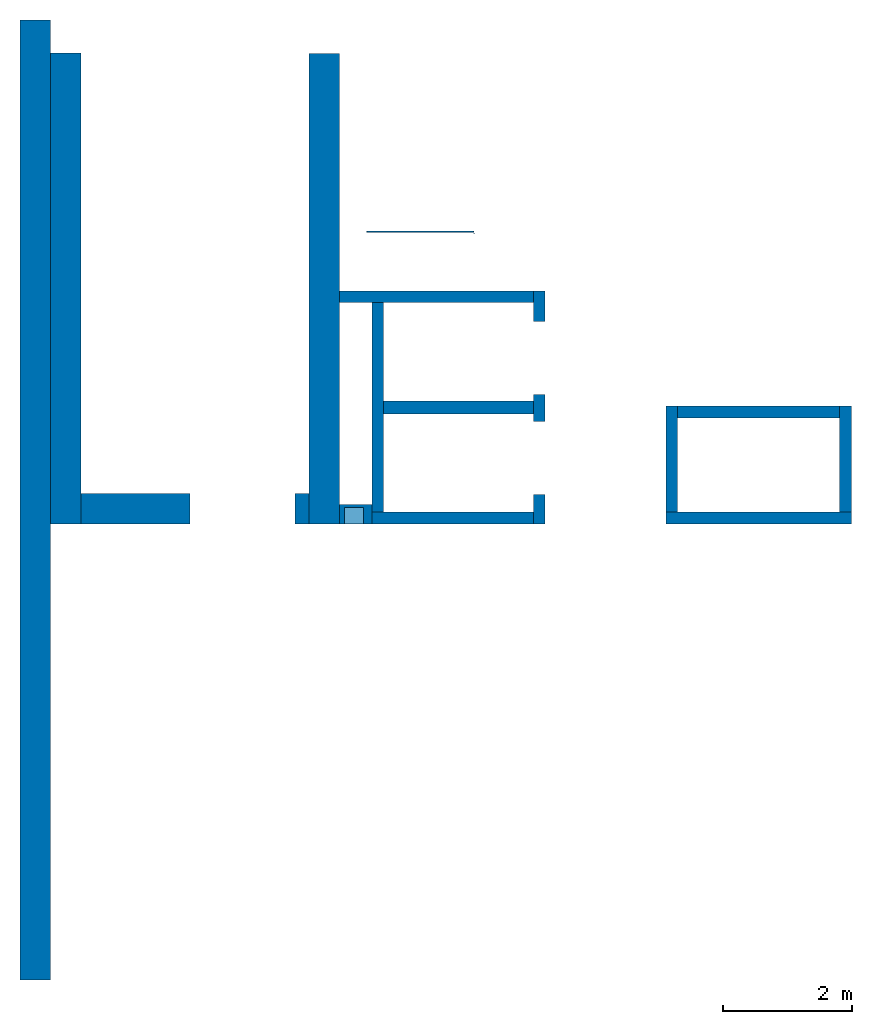
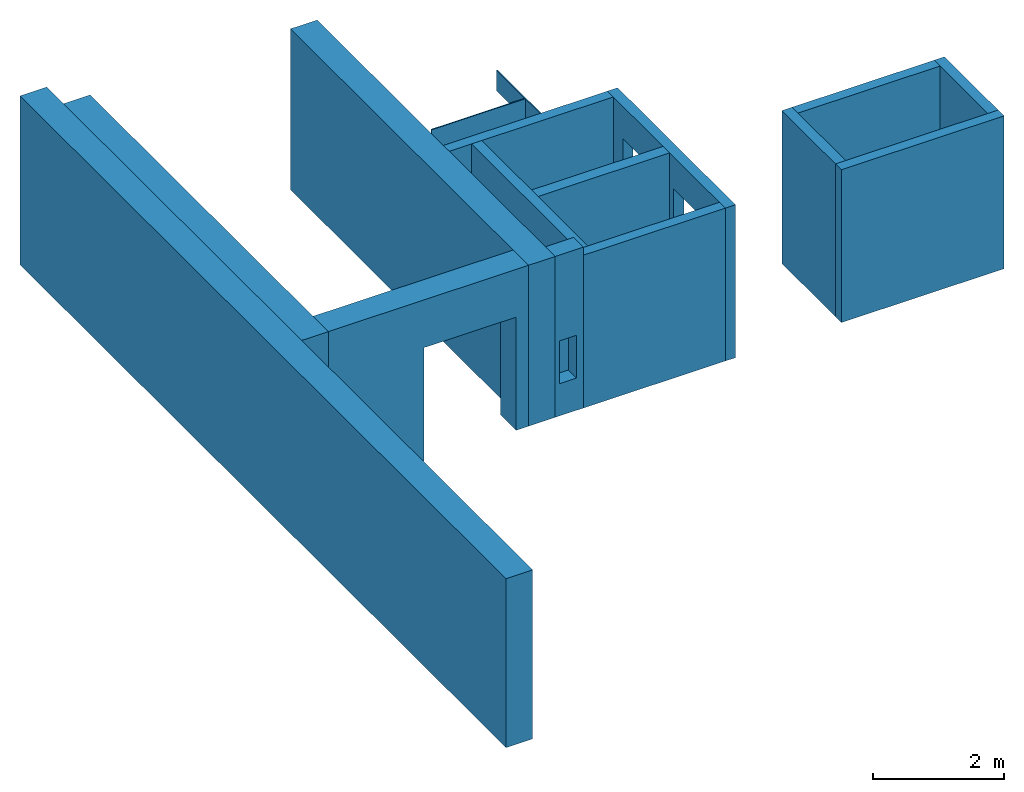
# One storey: 16 walls, 6 openings.
"""IFC4 building model written with IfcOpenShell, lengths in metres."""

from ifc_helpers import new_model, entity, si_unit, converted_unit, derived_unit, direction, frame, origin_with_axes, place, context, subcontext, project, spatial, polygons, material, type_object, element, save


model = new_model("IFC4")

# Units and contexts
model_context = context("Model", 3, precision=1e-05, world=origin_with_axes(), true_north=direction((0.0, 1.0)))
body_context = subcontext(model_context, "Body", "Model", "MODEL_VIEW")
ifc_project = project(units=[si_unit("LENGTHUNIT", "METRE"), si_unit("AREAUNIT", "SQUARE_METRE"), si_unit("VOLUMEUNIT", "CUBIC_METRE"), converted_unit("PLANEANGLEUNIT", "DEGREE", entity("IfcPlaneAngleMeasure", 0.0174532925199433), si_unit("PLANEANGLEUNIT", "RADIAN"), dimensions=[0, 0, 0, 0, 0, 0, 0]), converted_unit("TIMEUNIT", "Year", entity("IfcTimeMeasure", 31557600.0), si_unit("TIMEUNIT", "SECOND"), dimensions=[0, 0, 1, 0, 0, 0, 0]), si_unit("MASSUNIT", "GRAM", prefix="KILO"), si_unit("THERMODYNAMICTEMPERATUREUNIT", "DEGREE_CELSIUS"), si_unit("LUMINOUSINTENSITYUNIT", "LUMEN"), si_unit("ENERGYUNIT", "JOULE", prefix="MEGA"), derived_unit("THERMALCONDUCTANCEUNIT", [(si_unit("POWERUNIT", "WATT"), 1), (si_unit("LENGTHUNIT", "METRE"), -1), (si_unit("THERMODYNAMICTEMPERATUREUNIT", "KELVIN"), -1)]), derived_unit("SPECIFICHEATCAPACITYUNIT", [(si_unit("ENERGYUNIT", "JOULE"), 1), (si_unit("MASSUNIT", "GRAM", prefix="KILO"), -1), (si_unit("THERMODYNAMICTEMPERATUREUNIT", "KELVIN"), -1)]), derived_unit("MASSDENSITYUNIT", [(si_unit("MASSUNIT", "GRAM", prefix="KILO"), 1), (si_unit("VOLUMEUNIT", "CUBIC_METRE"), -1)])], contexts=[model_context])

# Site, building, storey
site_placement = place(None, origin_with_axes())
site = spatial("IfcSite", under=ifc_project, at=site_placement, CompositionType="ELEMENT")
building_placement = place(None, origin_with_axes())
building = spatial("IfcBuilding", under=site, at=building_placement, CompositionType="ELEMENT")
storey_placement = place(None, frame((0.0, 0.0, 7.5), z_axis=(0.0, 0.0, 1.0), x_axis=(1.0, 0.0, 0.0)))
storey = spatial("IfcBuildingStorey", under=building, at=storey_placement, Name="2 OG", CompositionType="ELEMENT", Elevation=7.5)

# Wall
ifc_material_1 = material(Name="Stahlbeton")
wall_type_1 = type_object("IfcWallType", Name="Stahlbeton 180", PredefinedType="NOTDEFINED")
wall_1_placement = place(None, frame((31.638, 10.6549999454676, 7.5), z_axis=(0.0, 0.0, 1.0), x_axis=(-1.0, 0.0, 0.0)))
element("IfcWall", 1, at=wall_1_placement, inside=storey, type_object=wall_type_1, material=ifc_material_1, Name="Wand-003", PredefinedType="NOTDEFINED", context=body_context, shape_type="Tessellation", body=[
    polygons([(3.18, 0.18, 2.85), (0.179999999999996, 0.18, 2.85), (0.179999999999996, 0.0, 2.85), (3.18, 0.0, 2.85), (3.18, 0.18, 0.0), (0.179999999999996, 0.18, 0.0), (0.179999999999996, 0.0, 0.0), (3.18, 0.0, 0.0)], [[[1, 2, 3, 4]], [[5, 6, 2, 1]], [[6, 7, 3, 2]], [[4, 3, 7, 8]], [[1, 4, 8, 5]], [[8, 7, 6, 5]]], closed=True),
])

# Wall, openings
wall_2_placement = place(None, frame((31.638, 7.05499994546755, 7.5), z_axis=(0.0, 0.0, 1.0), x_axis=(0.0, 1.0, 0.0)))
wall_2 = element("IfcWall", 2, at=wall_2_placement, inside=storey, type_object=wall_type_1, material=ifc_material_1, Name="Wand-002", PredefinedType="NOTDEFINED", context=body_context, shape_type="Tessellation", body=[
    polygons([(2.0, 0.0, 0.0), (2.0, 0.0, 2.25), (3.13, 0.0, 2.25), (3.13, 0.0, 0.0), (3.6, 0.0, 0.0), (3.6, 0.0, 2.85), (0.0, 0.0, 2.85), (0.0, 0.0, 0.0), (0.450000000000002, 0.0, 0.0), (0.450000000000002, 0.0, 2.25), (1.58, 0.0, 2.25), (1.58, 0.0, 0.0), (2.0, 0.179999999999996, 0.0), (2.0, 0.179999999999996, 2.25), (3.13, 0.179999999999996, 2.25), (3.13, 0.179999999999996, 0.0), (3.6, 0.179999999999996, 0.0), (3.6, 0.179999999999996, 2.85), (0.0, 0.18, 2.85), (0.0, 0.18, 0.0), (0.450000000000002, 0.18, 0.0), (0.450000000000002, 0.18, 2.25), (1.58, 0.18, 2.25), (1.58, 0.18, 0.0)], [[[1, 2, 3, 4, 5, 6, 7, 8, 9, 10, 11, 12]], [[2, 1, 13, 14]], [[3, 2, 14, 15]], [[4, 3, 15, 16]], [[4, 16, 17, 5]], [[6, 5, 17, 18]], [[6, 18, 19, 7]], [[19, 20, 8, 7]], [[9, 8, 20, 21]], [[9, 21, 22, 10]], [[10, 22, 23, 11]], [[11, 23, 24, 12]], [[13, 1, 12, 24]], [[14, 13, 24, 23, 22, 21, 20, 19, 18, 17, 16, 15]]], closed=True),
])
opening_1_placement = place(wall_2_placement, frame((1.015, 0.0, 0.0), z_axis=(0.0, 0.0, 1.0), x_axis=(1.0, 0.0, 0.0)))
element("IfcOpeningElement", 3, at=opening_1_placement, cuts=wall_2, context=body_context, identifier="Reference", shape_type="Tessellation", body=[
    polygons([(-0.565, -0.00100000000000122, 2.25), (-0.565, -0.00100000000000122, 0.0), (0.565, -0.00100000000000122, 0.0), (0.565, -0.00100000000000122, 2.25), (-0.565, 0.181000000000004, 2.25), (-0.565, 0.181000000000004, 0.0), (0.565000000000001, 0.181000000000004, 0.0), (0.565000000000001, 0.181000000000004, 2.25)], [[[1, 2, 3, 4]], [[5, 6, 2, 1]], [[6, 7, 3, 2]], [[7, 8, 4, 3]], [[8, 5, 1, 4]], [[7, 6, 5, 8]]], closed=True),
])
opening_2_placement = place(wall_2_placement, frame((2.565, 0.0, 0.0), z_axis=(0.0, 0.0, 1.0), x_axis=(1.0, 0.0, 0.0)))
element("IfcOpeningElement", 4, at=opening_2_placement, cuts=wall_2, context=body_context, identifier="Reference", shape_type="Tessellation", body=[
    polygons([(-0.565, -0.00100000000000478, 2.25), (-0.565, -0.00100000000000478, 0.0), (0.565, -0.00100000000000478, 0.0), (0.565, -0.00100000000000478, 2.25), (-0.564999999999998, 0.181000000000001, 2.25), (-0.564999999999998, 0.181000000000001, 0.0), (0.565000000000001, 0.181000000000001, 0.0), (0.565000000000001, 0.181000000000001, 2.25)], [[[1, 2, 3, 4]], [[5, 6, 2, 1]], [[6, 7, 3, 2]], [[7, 8, 4, 3]], [[8, 5, 1, 4]], [[7, 6, 5, 8]]], closed=True),
])

# Walls
wall_3_placement = place(None, frame((33.505, 7.05499994546756, 7.5), z_axis=(0.0, 0.0, 1.0), x_axis=(0.0, 1.0, 0.0)))
element("IfcWall", 5, at=wall_3_placement, inside=storey, type_object=wall_type_1, material=ifc_material_1, Name="Wand-001", PredefinedType="NOTDEFINED", context=body_context, shape_type="Tessellation", body=[
    polygons([(1.818, 0.0, 0.0), (1.818, 0.0, 2.85), (1.818, -0.18, 2.85), (1.818, -0.18, 0.0), (0.18, 0.0, 0.0), (0.180000000000001, 0.0, 2.85), (0.180000000000001, -0.18, 2.85), (0.18, -0.18, 0.0)], [[[1, 2, 3, 4]], [[5, 6, 2, 1]], [[6, 7, 3, 2]], [[4, 3, 7, 8]], [[4, 8, 5, 1]], [[8, 7, 6, 5]]], closed=True),
])
wall_4_placement = place(None, frame((28.958, 7.05499994546755, 7.5), z_axis=(0.0, 0.0, 1.0), x_axis=(1.0, 0.0, 0.0)))
element("IfcWall", 6, at=wall_4_placement, inside=storey, type_object=wall_type_1, material=ifc_material_1, Name="Wand-001", PredefinedType="NOTDEFINED", context=body_context, shape_type="Tessellation", body=[
    polygons([(0.0, 0.0, 2.85), (2.5, 0.0, 2.85), (2.5, 0.180000000000002, 2.85), (0.0, 0.18, 2.85), (0.0, 0.0, 0.0), (2.5, 0.0, 0.0), (2.5, 0.180000000000001, 0.0), (0.0, 0.18, 0.0)], [[[1, 2, 3, 4]], [[5, 6, 2, 1]], [[6, 7, 3, 2]], [[4, 3, 7, 8]], [[5, 1, 4, 8]], [[8, 7, 6, 5]]], closed=True),
])
wall_5_placement = place(None, frame((36.373, 8.87299994546756, 7.5), z_axis=(0.0, 0.0, 1.0), x_axis=(-1.0, 0.0, 0.0)))
element("IfcWall", 7, at=wall_5_placement, inside=storey, type_object=wall_type_1, material=ifc_material_1, Name="Wand-001", PredefinedType="NOTDEFINED", context=body_context, shape_type="Tessellation", body=[
    polygons([(2.688, 0.18, 2.85), (0.18, 0.18, 2.85), (0.18, 0.0, 2.85), (2.688, 0.0, 2.85), (2.688, 0.18, 0.0), (0.18, 0.18, 0.0), (0.18, 0.0, 0.0), (2.688, 0.0, 0.0)], [[[1, 2, 3, 4]], [[5, 6, 2, 1]], [[6, 7, 3, 2]], [[4, 3, 7, 8]], [[5, 1, 4, 8]], [[8, 7, 6, 5]]], closed=True),
])
wall_6_placement = place(None, frame((36.373, 7.05499994546756, 7.5), z_axis=(0.0, 0.0, 1.0), x_axis=(0.0, 1.0, 0.0)))
element("IfcWall", 8, at=wall_6_placement, inside=storey, type_object=wall_type_1, material=ifc_material_1, Name="Wand-001", PredefinedType="NOTDEFINED", context=body_context, shape_type="Tessellation", body=[
    polygons([(1.818, 0.18, 0.0), (1.818, 0.18, 2.85), (1.818, 0.0, 2.85), (1.818, 0.0, 0.0), (0.180000000000001, 0.18, 0.0), (0.180000000000001, 0.18, 2.85), (0.180000000000001, 0.0, 2.85), (0.180000000000001, 0.0, 0.0)], [[[1, 2, 3, 4]], [[5, 6, 2, 1]], [[6, 7, 3, 2]], [[4, 3, 7, 8]], [[4, 8, 5, 1]], [[8, 7, 6, 5]]], closed=True),
])
wall_7_placement = place(None, frame((33.505, 7.05499994546756, 7.5), z_axis=(0.0, 0.0, 1.0), x_axis=(1.0, 0.0, 0.0)))
element("IfcWall", 9, at=wall_7_placement, inside=storey, type_object=wall_type_1, material=ifc_material_1, Name="Wand-001", PredefinedType="NOTDEFINED", context=body_context, shape_type="Tessellation", body=[
    polygons([(0.0, 0.18, 0.0), (0.0, 0.18, 2.85), (2.868, 0.180000000000001, 2.84999999940395), (2.868, 0.180000000000001, 0.0), (0.0, 0.0, 0.0), (0.0, 0.0, 2.85), (2.868, 0.0, 2.84999999940395), (2.868, 0.0, 0.0)], [[[1, 2, 3, 4]], [[5, 6, 2, 1]], [[6, 7, 3, 2]], [[4, 3, 7, 8]], [[5, 1, 4, 8]], [[8, 7, 6, 5]]], closed=True),
])
wall_8_placement = place(None, frame((29.138, 7.05499994546755, 7.5), z_axis=(0.0, 0.0, 1.0), x_axis=(0.0, 1.0, 0.0)))
element("IfcWall", 10, at=wall_8_placement, inside=storey, type_object=wall_type_1, material=ifc_material_1, Name="Wand-003", PredefinedType="NOTDEFINED", context=body_context, shape_type="Tessellation", body=[
    polygons([(3.42, 0.18, 2.85), (0.180000000000001, 0.18, 2.85), (0.180000000000001, 0.0, 2.85), (3.42, 0.0, 2.85), (3.42, 0.18, 0.0), (0.18, 0.18, 0.0), (0.18, 0.0, 0.0), (3.42, 0.0, 0.0)], [[[1, 2, 3, 4]], [[5, 6, 2, 1]], [[6, 7, 3, 2]], [[4, 3, 7, 8]], [[5, 1, 4, 8]], [[8, 7, 6, 5]]], closed=True),
])

# Space
space_placement = place(None, frame((28.883, 12.4404999136732, 7.5), z_axis=(0.0, 0.0, 1.0), x_axis=(0.0, -1.0, 0.0)))
space = spatial("IfcSpace", under=storey, at=space_placement, CompositionType="ELEMENT", PredefinedType="NOTDEFINED")

# Wall
ifc_material_2 = material(Name="Kunststoff")
wall_type_2 = type_object("IfcWallType", Name="Kunststoff 20", PredefinedType="NOTDEFINED")
wall_9_placement = place(None, frame((30.553, 11.5727499295704, 7.35), z_axis=(0.0, 0.0, 1.0), x_axis=(-1.0, 0.0, 0.0)))
element("IfcWall", 11, at=wall_9_placement, inside=space, type_object=wall_type_2, material=ifc_material_2, Name="Wand-003", PredefinedType="NOTDEFINED", context=body_context, shape_type="Tessellation", body=[
    polygons([(0.0199999999999996, -0.00999999999999979, 2.63), (0.0199999999999996, 0.00999999999999979, 2.63), (0.0199999999999996, 0.00999999999999979, 0.15), (0.0199999999999996, -0.00999999999999979, 0.15), (1.67, -0.00999999999999979, 2.63), (1.67, 0.00999999999999979, 2.63), (1.67, 0.00999999999999979, 0.15), (1.67, -0.00999999999999979, 0.15)], [[[1, 2, 3, 4]], [[2, 1, 5, 6]], [[2, 6, 7, 3]], [[3, 7, 8, 4]], [[5, 1, 4, 8]], [[6, 5, 8, 7]]], closed=True),
])

# Wall, openings
wall_10_placement = place(None, frame((30.553, 10.6549999454676, 7.35), z_axis=(0.0, 0.0, 1.0), x_axis=(0.0, 1.0, 0.0)))
wall_10 = element("IfcWall", 12, at=wall_10_placement, inside=space, type_object=wall_type_2, material=ifc_material_2, Name="Wand-003", PredefinedType="NOTDEFINED", context=body_context, shape_type="Tessellation", body=[
    polygons([(0.895499968205613, 0.0, 0.15), (0.895499968205613, 0.0, 2.245), (1.78549996820561, 0.0, 2.245), (1.78549996820561, 0.0, 2.63), (0.0, 0.0, 2.63), (0.0, 0.0, 2.245), (0.890000000000001, 0.0, 2.245), (0.890000000000001, 0.0, 0.15), (0.895499968205613, 0.0199999999999996, 0.15), (0.895499968205613, 0.0199999999999996, 2.245), (1.78549996820561, 0.0199999999999996, 2.245), (1.78549996820561, 0.0199999999999996, 2.63), (0.0, 0.0199999999999996, 2.63), (0.0, 0.0199999999999996, 2.245), (0.890000000000001, 0.0199999999999996, 2.245), (0.890000000000001, 0.0199999999999996, 0.15)], [[[1, 2, 3, 4, 5, 6, 7, 8]], [[2, 1, 9, 10]], [[11, 3, 2, 10]], [[3, 11, 12, 4]], [[13, 5, 4, 12]], [[6, 5, 13, 14]], [[6, 14, 15, 7]], [[7, 15, 16, 8]], [[9, 1, 8, 16]], [[10, 9, 16, 15, 14, 13, 12, 11]]], closed=True),
])
opening_3_placement = place(wall_10_placement, frame((1.34049996820561, 0.0, 0.2), z_axis=(0.0, 0.0, 1.0), x_axis=(1.0, 0.0, 0.0)))
element("IfcOpeningElement", 13, at=opening_3_placement, cuts=wall_10, context=body_context, identifier="Reference", shape_type="Tessellation", body=[
    polygons([(0.445, 0.0210000000000008, 2.045), (0.445, 0.0210000000000008, -0.0499999999999998), (-0.445, 0.0210000000000008, -0.0499999999999998), (-0.445, 0.0210000000000008, 2.045), (0.445, -0.00100000000000122, 2.045), (0.445, -0.00100000000000122, -0.0499999999999998), (-0.445, -0.00100000000000122, -0.0499999999999998), (-0.445, -0.00100000000000122, 2.045)], [[[1, 2, 3, 4]], [[5, 6, 2, 1]], [[6, 7, 3, 2]], [[7, 8, 4, 3]], [[8, 5, 1, 4]], [[7, 6, 5, 8]]], closed=True),
])
opening_4_placement = place(wall_10_placement, frame((0.445, 0.0, 0.2), z_axis=(0.0, 0.0, 1.0), x_axis=(1.0, 0.0, 0.0)))
element("IfcOpeningElement", 14, at=opening_4_placement, cuts=wall_10, context=body_context, identifier="Reference", shape_type="Tessellation", body=[
    polygons([(0.445, 0.0210000000000008, 2.045), (0.445, 0.0210000000000008, -0.0499999999999998), (-0.445, 0.0210000000000008, -0.0499999999999998), (-0.445, 0.0210000000000008, 2.045), (0.445, -0.00100000000000122, 2.045), (0.445, -0.00100000000000122, -0.0499999999999998), (-0.445, -0.00100000000000122, -0.0499999999999998), (-0.445, -0.00100000000000122, 2.045)], [[[1, 2, 3, 4]], [[5, 6, 2, 1]], [[6, 7, 3, 2]], [[7, 8, 4, 3]], [[8, 5, 1, 4]], [[7, 6, 5, 8]]], closed=True),
])

# Walls
wall_type_3 = type_object("IfcWallType", Name="Stahlbeton 470", PredefinedType="NOTDEFINED")
wall_11_placement = place(None, frame((24.458, 14.3318657372406, 7.5), z_axis=(0.0, 0.0, 1.0), x_axis=(0.0, -1.0, 0.0)))
element("IfcWall", 15, at=wall_11_placement, inside=storey, type_object=wall_type_3, material=ifc_material_1, Name="Wand-001", PredefinedType="NOTDEFINED", context=body_context, shape_type="Tessellation", body=[
    polygons([(7.27686579177299, -0.470000000000002, 3.0), (7.27686579177299, 0.0, 3.0), (0.0, 0.0, 3.0), (0.0, -0.469999999999999, 3.0), (7.27686579177299, -0.470000000000002, 0.0), (7.27686579177299, 0.0, 0.0), (0.0, 0.0, 0.0), (0.0, -0.469999999999999, 0.0)], [[[1, 2, 3, 4]], [[2, 1, 5, 6]], [[2, 6, 7, 3]], [[8, 4, 3, 7]], [[5, 1, 4, 8]], [[6, 5, 8, 7]]], closed=True),
])
wall_12_placement = place(None, frame((23.988, 14.8459998818788, 7.35), z_axis=(0.0, 0.0, 1.0), x_axis=(0.0, -1.0, 0.0)))
element("IfcWall", 16, at=wall_12_placement, inside=storey, type_object=wall_type_3, material=ifc_material_1, Name="Wand-001", PredefinedType="NOTDEFINED", context=body_context, shape_type="Tessellation", body=[
    polygons([(0.0, 0.0, 0.0), (0.0, 0.0, 3.15), (14.8459998818788, 0.0, 3.15), (14.8459998818788, 0.0, 0.0), (0.362999990943669, 0.0, 3.0), (0.362999990943669, 0.0, 2.63), (7.79099993641123, 0.0, 2.63), (14.4829998818788, 0.0, 2.63), (14.4829998818788, 0.0, 3.0), (7.79099993641123, 0.0, 3.0), (0.0, -0.469999999999999, 0.0), (0.0, -0.469999999999999, 3.15), (14.8459998818788, -0.469999999999999, 3.15), (14.8459998818788, -0.469999999999999, 0.0), (0.362999990943669, -0.100000000000012, 2.63), (0.362999990943669, -0.100000000000012, 3.0), (14.4829998818788, -0.100000000000005, 2.63), (14.4829998818788, -0.100000000000005, 3.0)], [[[1, 2, 3, 4], [5, 6, 7, 8, 9, 10]], [[1, 11, 12, 2]], [[2, 12, 13, 3]], [[4, 3, 13, 14]], [[11, 1, 4, 14]], [[15, 6, 5, 16]], [[8, 7, 6, 15, 17]], [[18, 9, 8, 17]], [[18, 16, 5, 10, 9]], [[12, 11, 14, 13]], [[17, 15, 16, 18]]], closed=True),
])

# Wall, opening
wall_13_placement = place(None, frame((24.458, 7.52499994546755, 7.5), z_axis=(0.0, 0.0, 1.0), x_axis=(1.0, 0.0, 0.0)))
wall_13 = element("IfcWall", 17, at=wall_13_placement, inside=storey, type_object=wall_type_3, material=ifc_material_1, Name="Wand-001", PredefinedType="NOTDEFINED", context=body_context, shape_type="Tessellation", body=[
    polygons([(1.69000000000001, 0.0, 2.11), (1.69000000000001, 0.0, 0.0), (0.0, 0.0, 0.0), (0.0, 0.0, 3.0), (3.53, 0.0, 3.0), (3.53, 0.0, 0.0), (3.31, 0.0, 0.0), (3.31, 0.0, 2.11), (1.69000000000001, -0.47, 2.11), (1.69000000000001, -0.47, 0.0), (0.0, -0.47, 0.0), (0.0, -0.47, 3.0), (3.53, -0.47, 3.0), (3.53, -0.47, 0.0), (3.31, -0.47, 0.0), (3.31, -0.47, 2.11)], [[[1, 2, 3, 4, 5, 6, 7, 8]], [[2, 1, 9, 10]], [[2, 10, 11, 3]], [[12, 4, 3, 11]], [[5, 4, 12, 13]], [[13, 14, 6, 5]], [[15, 7, 6, 14]], [[8, 7, 15, 16]], [[1, 8, 16, 9]], [[16, 15, 14, 13, 12, 11, 10, 9]]], closed=True),
])
opening_5_placement = place(wall_13_placement, frame((2.5, 0.0, 0.0), z_axis=(0.0, 0.0, 1.0), x_axis=(1.0, 0.0, 0.0)))
element("IfcOpeningElement", 18, at=opening_5_placement, cuts=wall_13, context=body_context, identifier="Reference", shape_type="Tessellation", body=[
    polygons([(-0.809999999999999, -0.471, 2.11), (-0.809999999999999, -0.471, 0.0), (0.809999999999999, -0.471, 0.0), (0.809999999999999, -0.471, 2.11), (-0.809999999999999, 0.00100000000000033, 2.11), (-0.809999999999999, 0.00100000000000033, 0.0), (0.809999999999999, 0.00100000000000033, 0.0), (0.809999999999999, 0.00100000000000033, 2.11)], [[[1, 2, 3, 4]], [[5, 6, 2, 1]], [[6, 7, 3, 2]], [[7, 8, 4, 3]], [[8, 5, 1, 4]], [[7, 6, 5, 8]]], closed=True),
])

# Wall
wall_14_placement = place(None, frame((27.988, 14.3259998818788, 7.5), z_axis=(0.0, 0.0, 1.0), x_axis=(0.0, -1.0, 0.0)))
element("IfcWall", 19, at=wall_14_placement, inside=storey, type_object=wall_type_3, material=ifc_material_1, Name="Wand-001", PredefinedType="NOTDEFINED", context=body_context, shape_type="Tessellation", body=[
    polygons([(7.27099993641123, 0.469999999999999, 0.0), (7.27099993641123, 0.0, 0.0), (0.0, 0.0, 0.0), (0.0, 0.469999999999999, 0.0), (7.27099993641123, 0.469999999999999, 3.0), (7.27099993641123, 0.0, 3.0), (0.0, 0.0, 3.0), (0.0, 0.469999999999999, 3.0)], [[[1, 2, 3, 4]], [[2, 1, 5, 6]], [[2, 6, 7, 3]], [[8, 4, 3, 7]], [[5, 1, 4, 8]], [[6, 5, 8, 7]]], closed=True),
])

# Wall, opening
wall_type_4 = type_object("IfcWallType", Name="Stahlbeton 300", PredefinedType="NOTDEFINED")
wall_15_placement = place(None, frame((28.458, 7.05499994546755, 7.5), z_axis=(0.0, 0.0, 1.0), x_axis=(1.0, 0.0, 0.0)))
wall_15 = element("IfcWall", 20, at=wall_15_placement, inside=storey, type_object=wall_type_4, material=ifc_material_1, Name="Wand-001", PredefinedType="NOTDEFINED", context=body_context, shape_type="Tessellation", body=[
    polygons([(0.5, 0.0, 3.0), (0.0, 0.0, 3.0), (0.0, 0.0, 0.0), (0.5, 0.0, 0.0), (0.375425898351669, 0.0, 1.4), (0.375425898351669, 0.0, 0.6), (0.0754258983516713, 0.0, 0.6), (0.0754258983516713, 0.0, 1.4), (0.5, 0.3, 3.0), (0.0, 0.3, 3.0), (0.0, 0.3, 0.0), (0.5, 0.3, 0.0), (0.375425898351669, 0.25, 1.4), (0.375425898351669, 0.25, 0.6), (0.0754258983516713, 0.25, 0.6), (0.0754258983516713, 0.25, 1.4)], [[[1, 2, 3, 4], [5, 6, 7, 8]], [[9, 10, 2, 1]], [[3, 2, 10, 11]], [[4, 3, 11, 12]], [[9, 1, 4, 12]], [[13, 14, 6, 5]], [[14, 15, 7, 6]], [[15, 16, 8, 7]], [[16, 13, 5, 8]], [[12, 11, 10, 9]], [[16, 15, 14, 13]]], closed=True),
])
opening_6_placement = place(wall_15_placement, frame((-28.458, -7.05499994546755, -7.5), z_axis=(0.0, 0.0, 1.0), x_axis=(1.0, 0.0, 0.0)))
element("IfcOpeningElement", 21, at=opening_6_placement, cuts=wall_15, PredefinedType="NOTDEFINED", context=body_context, identifier="Reference", shape_type="Tessellation", body=[
    polygons([(28.5334258983517, 7.30499994546755, 8.1), (28.8334258983517, 7.30499994546755, 8.1), (28.8334258983517, 6.75499994546755, 8.1), (28.5334258983517, 6.75499994546755, 8.1), (28.5334258983517, 7.30499994546755, 8.9), (28.8334258983517, 7.30499994546755, 8.9), (28.8334258983517, 6.75499994546755, 8.9), (28.5334258983517, 6.75499994546755, 8.9)], [[[1, 2, 3, 4]], [[1, 5, 6, 2]], [[2, 6, 7, 3]], [[4, 3, 7, 8]], [[5, 1, 4, 8]], [[6, 5, 8, 7]]], closed=True),
])

# Wall
wall_type_5 = type_object("IfcWallType", Name="Stahlbeton 200", PredefinedType="NOTDEFINED")
wall_16_placement = place(None, frame((29.138, 8.85499994546755, 7.5), z_axis=(0.0, 0.0, 1.0), x_axis=(1.0, 0.0, 0.0)))
element("IfcWall", 22, at=wall_16_placement, inside=storey, type_object=wall_type_5, material=ifc_material_1, Name="Wand-001", PredefinedType="NOTDEFINED", context=body_context, shape_type="Tessellation", body=[
    polygons([(2.32, 0.0999999999999996, 0.0), (0.0, 0.0999999999999996, 0.0), (0.0, 0.0999999999999996, 2.85), (2.32, 0.0999999999999996, 2.85), (2.32, -0.0999999999999996, 0.0), (0.0, -0.0999999999999996, 0.0), (0.0, -0.0999999999999996, 2.85), (2.32, -0.0999999999999996, 2.85)], [[[1, 2, 3, 4]], [[5, 6, 2, 1]], [[6, 7, 3, 2]], [[4, 3, 7, 8]], [[5, 1, 4, 8]], [[8, 7, 6, 5]]], closed=True),
])

save(model, "model.ifc")
